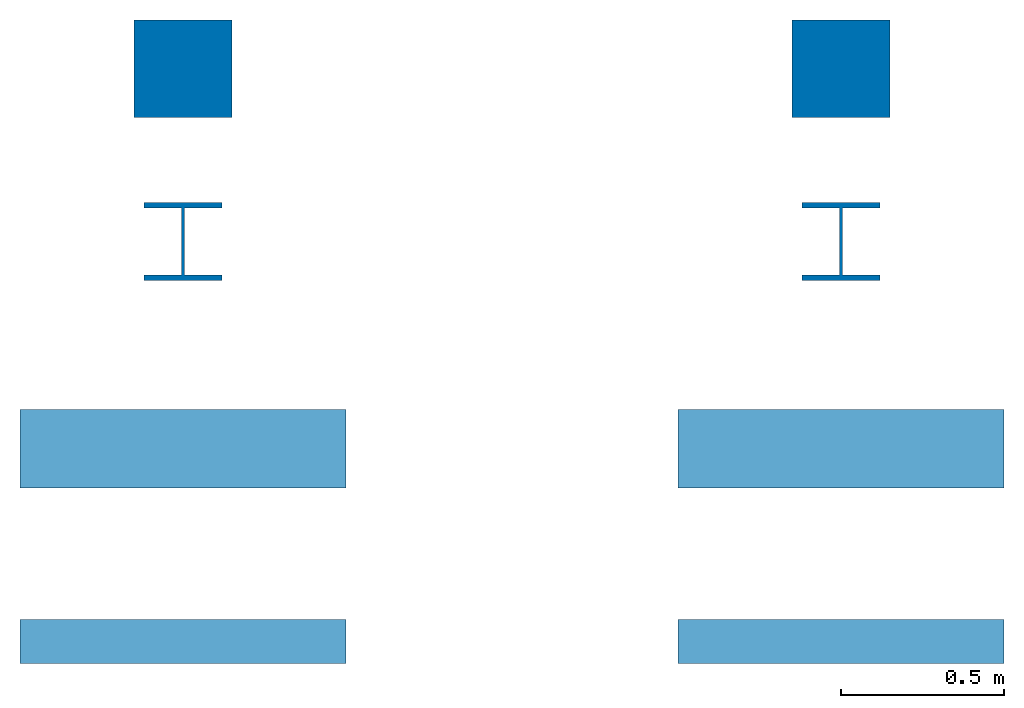
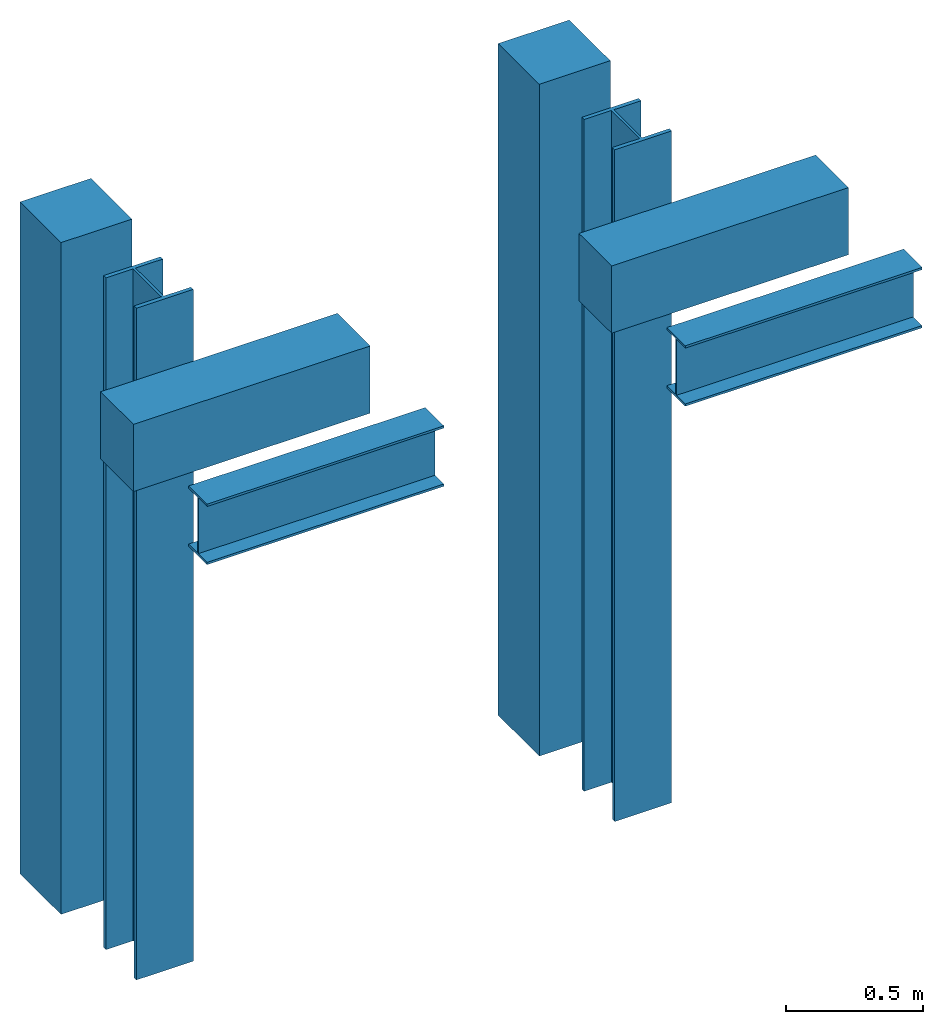
# One storey: 4 beams, 4 columns.
"""IFC2X3 building model written with IfcOpenShell, lengths in millimetres."""

from ifc_helpers import new_model, entity, si_unit, converted_unit, direction, frame, frame_2d, origin, origin_with_axes, place, context, subcontext, project, spatial, polyline, rectangle, outline, extrude, material, element, save


model = new_model("IFC2X3")

# Units and contexts
model_context = context("Model", 3, precision=1e-05, world=origin(), true_north=direction((0.1736481776669303, 0.9848077530122079)))
body_context = subcontext(model_context, "Body", "Model", "MODEL_VIEW")
ifc_project = project(units=[si_unit("LENGTHUNIT", "METRE", prefix="MILLI"), si_unit("AREAUNIT", "SQUARE_METRE", prefix="MILLI"), si_unit("VOLUMEUNIT", "CUBIC_METRE", prefix="MILLI"), si_unit("MASSUNIT", "GRAM", prefix="KILO"), converted_unit("PLANEANGLEUNIT", "DEGREE", entity("IfcPlaneAngleMeasure", 0.0174532925199433), si_unit("PLANEANGLEUNIT", "RADIAN"), dimensions=[0, 0, 0, 0, 0, 0, 0])], contexts=[model_context])

# Site, building, storey
site_placement = place(None, origin())
site = spatial("IfcSite", under=ifc_project, at=site_placement, CompositionType="ELEMENT")
building_placement = place(site_placement, origin())
building = spatial("IfcBuilding", under=site, at=building_placement, CompositionType="ELEMENT")
storey_placement = place(building_placement, origin())
storey = spatial("IfcBuildingStorey", under=building, at=storey_placement, Name="P0", CompositionType="ELEMENT", Elevation=0.0)

# Columns
ifc_material_1 = material(Name="Material_Concrete")
column_1_placement = place(storey_placement, frame((-14811.25411234743, 2126.605645927717, 0.0)))
element("IfcColumn", 1, at=column_1_placement, inside=storey, material=ifc_material_1, Name="Name_Column_Concrete_Rect_30x30", context=body_context, shape_type="SweptSolid", body=[
    extrude(rectangle(XDim=300.0, YDim=300.0, at=frame_2d((150.0, 150.0), x_axis=(1.0, 0.0))), origin_with_axes(), (0.0, 0.0, 1.0), 3000.0),
])
ifc_material_2 = material(Name="Material_Steel")
column_2_placement = place(storey_placement, frame((-14781.25411234743, 1626.605645927717, 0.0)))
element("IfcColumn", 2, at=column_2_placement, inside=storey, material=ifc_material_2, Name="Name_Column_Steel_HEB_240", context=body_context, shape_type="SweptSolid", body=[
    extrude(outline(polyline([(0.0, 223.0), (115.0, 223.0), (115.0, 17.0), (0.0, 17.0), (0.0, 0.0), (240.0, 0.0), (240.0, 17.0), (125.0, 17.0), (125.0, 223.0), (240.0, 223.0), (240.0, 240.0), (0.0, 240.0), (0.0, 223.0)])), origin_with_axes(), (0.0, 0.0, 1.0), 3000.0),
])
ifc_material_3 = material(Name="Material_Concrete")
column_3_placement = place(storey_placement, frame((-12791.25411234743, 2126.605645927717, 0.0)))
element("IfcColumn", 3, at=column_3_placement, inside=storey, material=ifc_material_3, Name="Name_Column_Concrete_Rect_30x30", context=body_context, shape_type="SweptSolid", body=[
    extrude(rectangle(XDim=300.0, YDim=300.0, at=frame_2d((150.0, 150.0), x_axis=(1.0, 0.0))), origin_with_axes(), (0.0, 0.0, 1.0), 3000.0),
])
ifc_material_4 = material(Name="Material_Concrete")
column_4_placement = place(storey_placement, frame((-12761.25411234743, 1626.605645927717, 0.0)))
element("IfcColumn", 4, at=column_4_placement, inside=storey, material=ifc_material_4, Name="Name_Column_Steel_HEB_240", context=body_context, shape_type="SweptSolid", body=[
    extrude(outline(polyline([(0.0, 223.0), (115.0, 223.0), (115.0, 17.0), (0.0, 17.0), (0.0, 0.0), (240.0, 0.0), (240.0, 17.0), (125.0, 17.0), (125.0, 223.0), (240.0, 223.0), (240.0, 240.0), (0.0, 240.0), (0.0, 223.0)])), origin_with_axes(), (0.0, 0.0, 1.0), 3000.0),
])

# Beams
ifc_material_5 = material(Name="Material_Concrete")
beam_1_placement = place(storey_placement, frame((-15161.25411234743, 990.4481803222844, 2700.0)))
element("IfcBeam", 5, at=beam_1_placement, inside=storey, material=ifc_material_5, Name="Name_Column_Beam_Rect_30x24", context=body_context, shape_type="SweptSolid", body=[
    extrude(rectangle(XDim=240.0000000000001, YDim=300.0, at=frame_2d((120.0000000000001, 150.0), x_axis=(1.0, 0.0))), frame((0.0, 0.0, 0.0), z_axis=(1.0, 0.0, 0.0), x_axis=(0.0, 1.0, 0.0)), (0.0, 0.0, 1.0), 1000.0),
])
ifc_material_6 = material(Name="Material_Steel")
beam_2_placement = place(storey_placement, frame((-15161.25411234743, 451.8307701941436, 2700.0), z_axis=(0.0, 0.0, 1.0), x_axis=(1.0, -2.273736754432321e-16, 0.0)))
element("IfcBeam", 6, at=beam_2_placement, inside=storey, material=ifc_material_6, Name="Name_Beam_Steel_IPE_270", context=body_context, shape_type="SweptSolid", body=[
    extrude(outline(polyline([(10.20000000000073, 0.0), (10.20000000000073, 64.20000000000003), (259.8000000000011, 64.20000000000003), (259.8000000000011, 0.0), (270.0000000000018, 0.0), (270.0000000000018, 135.0000000000001), (259.8000000000011, 135.0000000000001), (259.8000000000011, 70.80000000000003), (10.20000000000073, 70.80000000000003), (10.20000000000073, 135.0000000000001), (0.0, 135.0000000000001), (0.0, 0.0), (10.20000000000073, 0.0)])), frame((0.0, 135.0000000000001, 0.0), z_axis=(1.0, 0.0, 0.0), x_axis=(0.0, 0.0, 1.0)), (0.0, 0.0, 1.0), 1000.0),
])
ifc_material_7 = material(Name="Material_Concrete")
beam_3_placement = place(storey_placement, frame((-13141.25411234743, 990.4481803222844, 2700.0)))
element("IfcBeam", 7, at=beam_3_placement, inside=storey, material=ifc_material_7, Name="Name_Column_Beam_Rect_30x24", context=body_context, shape_type="SweptSolid", body=[
    extrude(rectangle(XDim=240.0000000000001, YDim=300.0, at=frame_2d((120.0000000000001, 150.0), x_axis=(1.0, 0.0))), frame((0.0, 0.0, 0.0), z_axis=(1.0, 0.0, 0.0), x_axis=(0.0, 1.0, 0.0)), (0.0, 0.0, 1.0), 1000.0),
])
ifc_material_8 = material(Name="Material_Steel")
beam_4_placement = place(storey_placement, frame((-13141.25411234743, 451.8307701941437, 2700.0), z_axis=(0.0, 0.0, 1.0), x_axis=(1.0, -1.13686837721616e-16, 0.0)))
element("IfcBeam", 8, at=beam_4_placement, inside=storey, material=ifc_material_8, Name="Name_Beam_Steel_IPE_270", context=body_context, shape_type="SweptSolid", body=[
    extrude(outline(polyline([(10.20000000000073, 0.0), (10.20000000000073, 64.2), (259.8000000000011, 64.2), (259.8000000000011, 0.0), (270.0000000000018, 0.0), (270.0000000000018, 135.0), (259.8000000000011, 135.0), (259.8000000000011, 70.8), (10.20000000000073, 70.8), (10.20000000000073, 135.0), (0.0, 135.0), (0.0, 0.0), (10.20000000000073, 0.0)])), frame((0.0, 135.0, 0.0), z_axis=(1.0, 0.0, 0.0), x_axis=(0.0, 0.0, 1.0)), (0.0, 0.0, 1.0), 1000.0),
])

save(model, "model.ifc")
